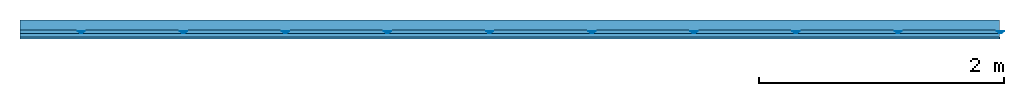
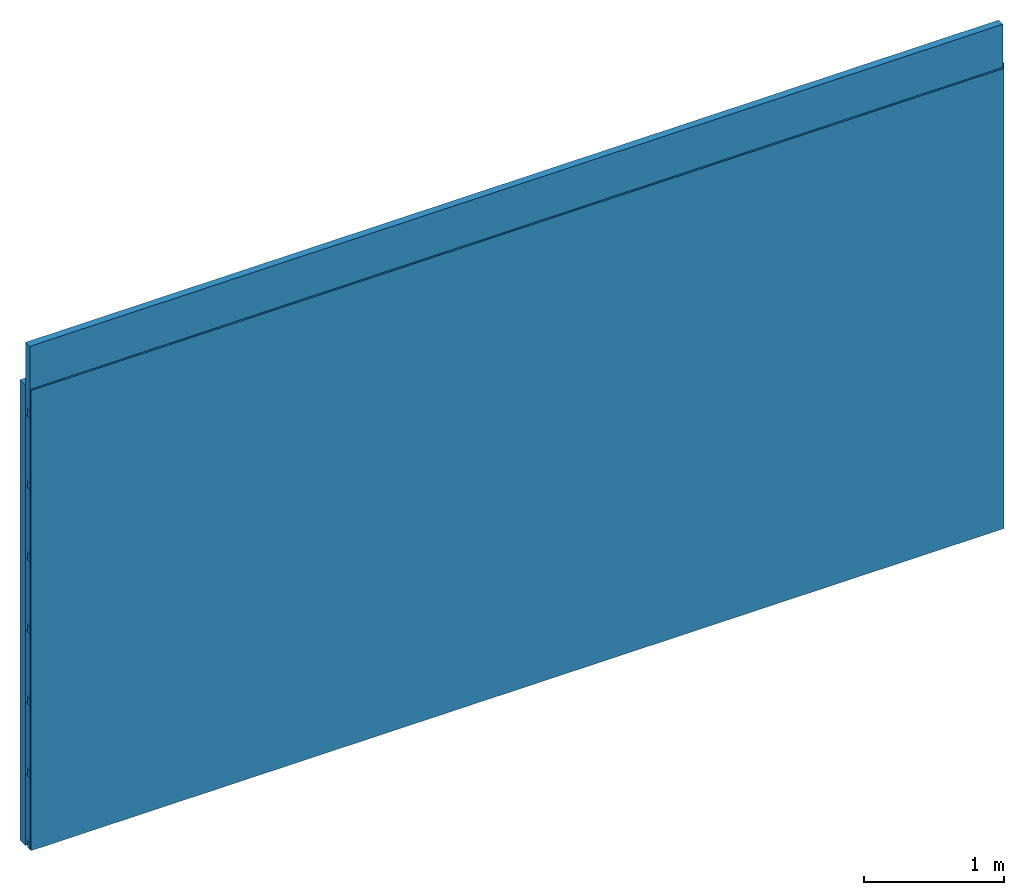
# One storey: 4 members, 1 plate, 1 element without a shape of its own.
"""IFC4 building model written with IfcOpenShell, lengths in metres."""

from ifc_helpers import new_model, si_unit, derived_unit, direction, frame, frame_2d, origin, place, context, project, spatial, polyline, rectangle, outline, extrude, material, layer, layer_set, type_object, element, aggregate, save


model = new_model("IFC4")

# Units and contexts
plan_context = context("Plan", 3, precision=1e-05, world=origin(), true_north=direction((0.0, 1.0)))
model_context = context("Model", 3, precision=1e-05, world=origin(), true_north=direction((0.0, 1.0)))
ifc_project = project(units=[si_unit("LENGTHUNIT", "METRE"), derived_unit("SOUNDPRESSUREUNIT", [(si_unit("PRESSUREUNIT", "PASCAL", prefix="MICRO"), 0)]), si_unit("ENERGYUNIT", "JOULE", prefix="MEGA"), si_unit("MASSUNIT", "GRAM", prefix="KILO"), derived_unit("THERMALTRANSMITTANCEUNIT", [(si_unit("POWERUNIT", "WATT"), 1), (si_unit("AREAUNIT", "SQUARE_METRE"), -1), (si_unit("THERMODYNAMICTEMPERATUREUNIT", "KELVIN"), -1)]), derived_unit("AREADENSITYUNIT", [(si_unit("MASSUNIT", "GRAM", prefix="KILO"), 1), (si_unit("AREAUNIT", "SQUARE_METRE"), -1)]), derived_unit("USERDEFINED", [(si_unit("ENERGYUNIT", "JOULE", prefix="MEGA"), 1), (si_unit("AREAUNIT", "SQUARE_METRE"), -1)])], contexts=[plan_context, model_context])

# Site, building, storey
site = spatial("IfcSite", under=ifc_project)
building_placement = place(None, origin())
building = spatial("IfcBuilding", under=site, at=building_placement)
storey_placement = place(building_placement, origin())
storey = spatial("IfcBuildingStorey", under=building, at=storey_placement)

# Wall, members, plate
ifc_layer_1 = layer(None, 0.08, Name="Support")
ifc_material_1 = material(Name="no composite action")
ifc_layer_2 = layer(ifc_material_1, 0.0, Name="Bond")
ifc_layer_3 = layer(None, 0.03, Name="Coupling")
ifc_layer_4 = layer(None, 0.03, Name="Battens / profiles")
ifc_material_2 = material(Category="03.007")
ifc_layer_5 = layer(ifc_material_2, 0.015, Name="Covering 1st layer")
ifc_material_3 = material(Name="Glued joints")
ifc_layer_6 = layer(ifc_material_3, 0.0, Name="Surface")
ifc_layer_set = layer_set([ifc_layer_1, ifc_layer_2, ifc_layer_3, ifc_layer_4, ifc_layer_5, ifc_layer_6])
wall_type = type_object("IfcWallType", Name="C0103", PredefinedType="NOTDEFINED", material=ifc_layer_set)
wall_placement = place(None, frame((0.0, 0.0, 0.0), z_axis=(0.0, -1.0, 0.0), x_axis=(1.0, 0.0, 0.0)))
wall = element("IfcWall", 1, at=wall_placement, inside=storey, type_object=wall_type, material=ifc_layer_set, Name="Wall #1")
ifc_material_4 = material()
member_1_placement = place(wall_placement, origin())
member_1 = element("IfcMember", 2, at=member_1_placement, material=ifc_material_4, Name="Support", context=plan_context, shape_type="SweptSolid", body=[
    extrude(rectangle(XDim=1.0, YDim=0.08, at=frame_2d((0.5, 0.04), x_axis=(1.0, 0.0))), frame((0.0, 4.0, 0.0), z_axis=(0.0, -1.0, 0.0), x_axis=(1.0, 0.0, 0.0)), (0.0, 0.0, 1.0), 4.0),
    extrude(rectangle(XDim=1.0, YDim=0.08, at=frame_2d((0.5, 0.04), x_axis=(1.0, 0.0))), frame((1.0, 4.0, 0.0), z_axis=(0.0, -1.0, 0.0), x_axis=(1.0, 0.0, 0.0)), (0.0, 0.0, 1.0), 4.0),
    extrude(rectangle(XDim=1.0, YDim=0.08, at=frame_2d((0.5, 0.04), x_axis=(1.0, 0.0))), frame((2.0, 4.0, 0.0), z_axis=(0.0, -1.0, 0.0), x_axis=(1.0, 0.0, 0.0)), (0.0, 0.0, 1.0), 4.0),
    extrude(rectangle(XDim=1.0, YDim=0.08, at=frame_2d((0.5, 0.04), x_axis=(1.0, 0.0))), frame((3.0, 4.0, 0.0), z_axis=(0.0, -1.0, 0.0), x_axis=(1.0, 0.0, 0.0)), (0.0, 0.0, 1.0), 4.0),
    extrude(rectangle(XDim=1.0, YDim=0.08, at=frame_2d((0.5, 0.04), x_axis=(1.0, 0.0))), frame((4.0, 4.0, 0.0), z_axis=(0.0, -1.0, 0.0), x_axis=(1.0, 0.0, 0.0)), (0.0, 0.0, 1.0), 4.0),
    extrude(rectangle(XDim=1.0, YDim=0.08, at=frame_2d((0.5, 0.04), x_axis=(1.0, 0.0))), frame((5.0, 4.0, 0.0), z_axis=(0.0, -1.0, 0.0), x_axis=(1.0, 0.0, 0.0)), (0.0, 0.0, 1.0), 4.0),
    extrude(rectangle(XDim=1.0, YDim=0.08, at=frame_2d((0.5, 0.04), x_axis=(1.0, 0.0))), frame((6.0, 4.0, 0.0), z_axis=(0.0, -1.0, 0.0), x_axis=(1.0, 0.0, 0.0)), (0.0, 0.0, 1.0), 4.0),
    extrude(rectangle(XDim=1.0, YDim=0.08, at=frame_2d((0.5, 0.04), x_axis=(1.0, 0.0))), frame((7.0, 4.0, 0.0), z_axis=(0.0, -1.0, 0.0), x_axis=(1.0, 0.0, 0.0)), (0.0, 0.0, 1.0), 4.0),
])
ifc_material_5 = material()
member_2_placement = place(wall_placement, origin())
member_2 = element("IfcMember", 3, at=member_2_placement, material=ifc_material_5, Name="Coupling", context=plan_context, shape_type="SweptSolid", body=[
    extrude(outline(polyline([(0.0, 0.0), (0.06, 0.0), (0.04, 0.02), (0.02, 0.02), (0.0, 0.0)])), frame((0.47, 4.0, 0.09), z_axis=(0.0, -1.0, 0.0), x_axis=(1.0, 0.0, 0.0)), (0.0, 0.0, 1.0), 4.0),
    extrude(outline(polyline([(0.0, 0.0), (0.06, 0.0), (0.04, 0.02), (0.02, 0.02), (0.0, 0.0)])), frame((1.304, 4.0, 0.09), z_axis=(0.0, -1.0, 0.0), x_axis=(1.0, 0.0, 0.0)), (0.0, 0.0, 1.0), 4.0),
    extrude(outline(polyline([(0.0, 0.0), (0.06, 0.0), (0.04, 0.02), (0.02, 0.02), (0.0, 0.0)])), frame((2.138, 4.0, 0.09), z_axis=(0.0, -1.0, 0.0), x_axis=(1.0, 0.0, 0.0)), (0.0, 0.0, 1.0), 4.0),
    extrude(outline(polyline([(0.0, 0.0), (0.06, 0.0), (0.04, 0.02), (0.02, 0.02), (0.0, 0.0)])), frame((2.972, 4.0, 0.09), z_axis=(0.0, -1.0, 0.0), x_axis=(1.0, 0.0, 0.0)), (0.0, 0.0, 1.0), 4.0),
    extrude(outline(polyline([(0.0, 0.0), (0.06, 0.0), (0.04, 0.02), (0.02, 0.02), (0.0, 0.0)])), frame((3.806, 4.0, 0.09), z_axis=(0.0, -1.0, 0.0), x_axis=(1.0, 0.0, 0.0)), (0.0, 0.0, 1.0), 4.0),
    extrude(outline(polyline([(0.0, 0.0), (0.06, 0.0), (0.04, 0.02), (0.02, 0.02), (0.0, 0.0)])), frame((4.64, 4.0, 0.09), z_axis=(0.0, -1.0, 0.0), x_axis=(1.0, 0.0, 0.0)), (0.0, 0.0, 1.0), 4.0),
    extrude(outline(polyline([(0.0, 0.0), (0.06, 0.0), (0.04, 0.02), (0.02, 0.02), (0.0, 0.0)])), frame((5.474, 4.0, 0.09), z_axis=(0.0, -1.0, 0.0), x_axis=(1.0, 0.0, 0.0)), (0.0, 0.0, 1.0), 4.0),
    extrude(outline(polyline([(0.0, 0.0), (0.06, 0.0), (0.04, 0.02), (0.02, 0.02), (0.0, 0.0)])), frame((6.308, 4.0, 0.09), z_axis=(0.0, -1.0, 0.0), x_axis=(1.0, 0.0, 0.0)), (0.0, 0.0, 1.0), 4.0),
    extrude(outline(polyline([(0.0, 0.0), (0.06, 0.0), (0.04, 0.02), (0.02, 0.02), (0.0, 0.0)])), frame((7.142, 4.0, 0.09), z_axis=(0.0, -1.0, 0.0), x_axis=(1.0, 0.0, 0.0)), (0.0, 0.0, 1.0), 4.0),
    extrude(outline(polyline([(0.0, 0.0), (0.06, 0.0), (0.04, 0.02), (0.02, 0.02), (0.0, 0.0)])), frame((7.976, 4.0, 0.09), z_axis=(0.0, -1.0, 0.0), x_axis=(1.0, 0.0, 0.0)), (0.0, 0.0, 1.0), 4.0),
])
member_3_placement = place(wall_placement, origin())
member_3 = element("IfcMember", 4, at=member_3_placement, material=ifc_material_5, Name="Battens / profiles", context=plan_context, shape_type="SweptSolid", body=[
    extrude(rectangle(XDim=0.06, YDim=0.03, at=frame_2d((0.03, 0.015), x_axis=(1.0, 0.0))), frame((0.0, 0.0, 0.11), z_axis=(1.0, 0.0, 0.0), x_axis=(0.0, 1.0, 0.0)), (0.0, 0.0, 1.0), 8.0),
    extrude(rectangle(XDim=0.06, YDim=0.03, at=frame_2d((0.03, 0.015), x_axis=(1.0, 0.0))), frame((0.0, 0.625, 0.11), z_axis=(1.0, 0.0, 0.0), x_axis=(0.0, 1.0, 0.0)), (0.0, 0.0, 1.0), 8.0),
    extrude(rectangle(XDim=0.06, YDim=0.03, at=frame_2d((0.03, 0.015), x_axis=(1.0, 0.0))), frame((0.0, 1.25, 0.11), z_axis=(1.0, 0.0, 0.0), x_axis=(0.0, 1.0, 0.0)), (0.0, 0.0, 1.0), 8.0),
    extrude(rectangle(XDim=0.06, YDim=0.03, at=frame_2d((0.03, 0.015), x_axis=(1.0, 0.0))), frame((0.0, 1.875, 0.11), z_axis=(1.0, 0.0, 0.0), x_axis=(0.0, 1.0, 0.0)), (0.0, 0.0, 1.0), 8.0),
    extrude(rectangle(XDim=0.06, YDim=0.03, at=frame_2d((0.03, 0.015), x_axis=(1.0, 0.0))), frame((0.0, 2.5, 0.11), z_axis=(1.0, 0.0, 0.0), x_axis=(0.0, 1.0, 0.0)), (0.0, 0.0, 1.0), 8.0),
    extrude(rectangle(XDim=0.06, YDim=0.03, at=frame_2d((0.03, 0.015), x_axis=(1.0, 0.0))), frame((0.0, 3.125, 0.11), z_axis=(1.0, 0.0, 0.0), x_axis=(0.0, 1.0, 0.0)), (0.0, 0.0, 1.0), 8.0),
    extrude(rectangle(XDim=0.06, YDim=0.03, at=frame_2d((0.03, 0.015), x_axis=(1.0, 0.0))), frame((0.0, 3.75, 0.11), z_axis=(1.0, 0.0, 0.0), x_axis=(0.0, 1.0, 0.0)), (0.0, 0.0, 1.0), 8.0),
])
ifc_material_6 = material()
member_4_placement = place(wall_placement, origin())
member_4 = element("IfcMember", 5, at=member_4_placement, material=ifc_material_6, Name="Cavity", context=plan_context, shape_type="SweptSolid", body=[
    extrude(rectangle(XDim=0.565, YDim=0.06, at=frame_2d((0.2825, 0.03), x_axis=(1.0, 0.0))), frame((0.0, 0.06, 0.08), z_axis=(1.0, 0.0, 0.0), x_axis=(0.0, 1.0, 0.0)), (0.0, 0.0, 1.0), 8.0),
    extrude(rectangle(XDim=0.565, YDim=0.06, at=frame_2d((0.2825, 0.03), x_axis=(1.0, 0.0))), frame((0.0, 0.685, 0.08), z_axis=(1.0, 0.0, 0.0), x_axis=(0.0, 1.0, 0.0)), (0.0, 0.0, 1.0), 8.0),
    extrude(rectangle(XDim=0.565, YDim=0.06, at=frame_2d((0.2825, 0.03), x_axis=(1.0, 0.0))), frame((0.0, 1.31, 0.08), z_axis=(1.0, 0.0, 0.0), x_axis=(0.0, 1.0, 0.0)), (0.0, 0.0, 1.0), 8.0),
    extrude(rectangle(XDim=0.565, YDim=0.06, at=frame_2d((0.2825, 0.03), x_axis=(1.0, 0.0))), frame((0.0, 1.935, 0.08), z_axis=(1.0, 0.0, 0.0), x_axis=(0.0, 1.0, 0.0)), (0.0, 0.0, 1.0), 8.0),
    extrude(rectangle(XDim=0.565, YDim=0.06, at=frame_2d((0.2825, 0.03), x_axis=(1.0, 0.0))), frame((0.0, 2.56, 0.08), z_axis=(1.0, 0.0, 0.0), x_axis=(0.0, 1.0, 0.0)), (0.0, 0.0, 1.0), 8.0),
    extrude(rectangle(XDim=0.565, YDim=0.06, at=frame_2d((0.2825, 0.03), x_axis=(1.0, 0.0))), frame((0.0, 3.185, 0.08), z_axis=(1.0, 0.0, 0.0), x_axis=(0.0, 1.0, 0.0)), (0.0, 0.0, 1.0), 8.0),
    extrude(rectangle(XDim=0.565, YDim=0.06, at=frame_2d((0.2825, 0.03), x_axis=(1.0, 0.0))), frame((0.0, 3.81, 0.08), z_axis=(1.0, 0.0, 0.0), x_axis=(0.0, 1.0, 0.0)), (0.0, 0.0, 1.0), 8.0),
])
plate_placement = place(wall_placement, origin())
plate = element("IfcPlate", 6, at=plate_placement, material=ifc_material_2, Name="Covering 1st layer", context=plan_context, shape_type="SweptSolid", body=[
    extrude(rectangle(XDim=8.0, YDim=4.0, at=frame_2d((4.0, 2.0), x_axis=(1.0, 0.0))), frame((0.0, 0.0, 0.14), z_axis=(0.0, 0.0, 1.0), x_axis=(1.0, 0.0, 0.0)), (0.0, 0.0, 1.0), 0.015),
])
aggregate(wall, [member_1, member_2, member_3, member_4, plate])

save(model, "model.ifc")
